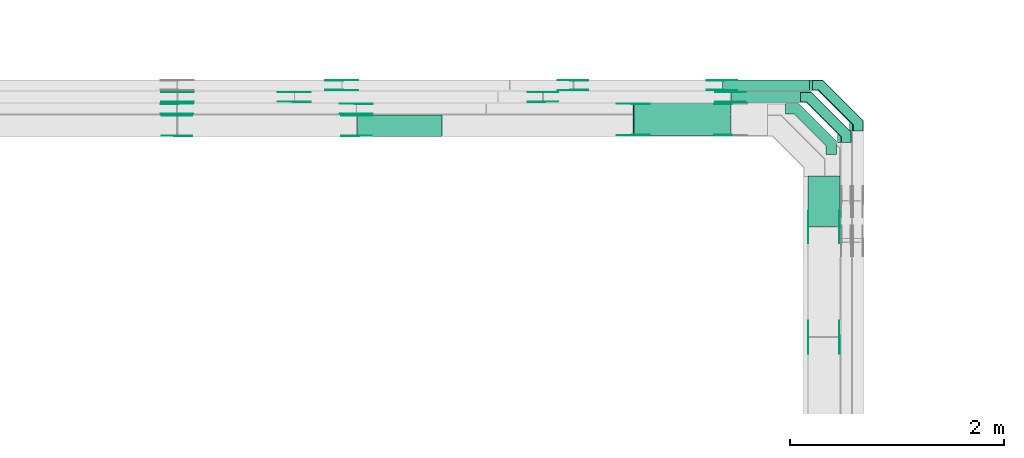
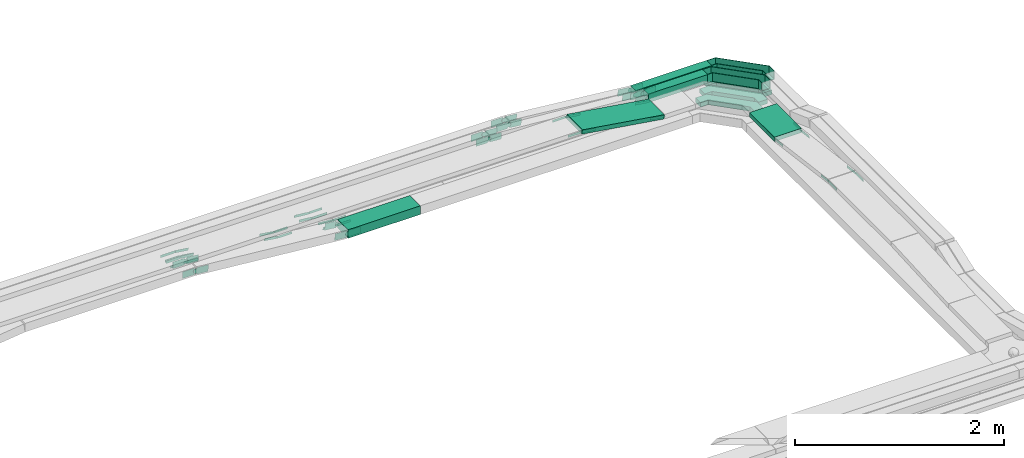
# One storey, part 24 of 33: 63 flow fittings, 5 flow segments.
"""IFC2X3 building model written with IfcOpenShell, lengths in millimetres."""

from ifc_helpers import new_model, entity, si_unit, converted_unit, derived_unit, direction, frame, frame_2d, origin, origin_2d_with_axis, place, context, subcontext, project, spatial, polyline, circle_curve, parameter, trimmed, segment, composite_curve, rectangle, outline, extrude, faceted_brep, source, transform, mapped, material, type_object, type_shapes, element, save


model = new_model("IFC2X3")

# Units and contexts
model_context = context("Model", 3, precision=0.01, world=origin(), true_north=direction((6.12303176911189e-17, 1.0)))
body_context = subcontext(model_context, "Body", "Model", "MODEL_VIEW")
ifc_project = project(units=[si_unit("LENGTHUNIT", "METRE", prefix="MILLI"), si_unit("AREAUNIT", "SQUARE_METRE"), si_unit("VOLUMEUNIT", "CUBIC_METRE"), converted_unit("PLANEANGLEUNIT", "DEGREE", entity("IfcRatioMeasure", 0.0174532925199433), si_unit("PLANEANGLEUNIT", "RADIAN"), dimensions=[0, 0, 0, 0, 0, 0, 0]), si_unit("MASSUNIT", "GRAM", prefix="KILO"), derived_unit("MASSDENSITYUNIT", [(si_unit("MASSUNIT", "GRAM", prefix="KILO"), 1), (si_unit("LENGTHUNIT", "METRE"), -3)]), derived_unit("MOMENTOFINERTIAUNIT", [(si_unit("LENGTHUNIT", "METRE"), 4)]), si_unit("TIMEUNIT", "SECOND"), si_unit("FREQUENCYUNIT", "HERTZ"), si_unit("THERMODYNAMICTEMPERATUREUNIT", "DEGREE_CELSIUS"), derived_unit("THERMALTRANSMITTANCEUNIT", [(si_unit("MASSUNIT", "GRAM", prefix="KILO"), 1), (si_unit("THERMODYNAMICTEMPERATUREUNIT", "KELVIN"), -1), (si_unit("TIMEUNIT", "SECOND"), -3)]), derived_unit("VOLUMETRICFLOWRATEUNIT", [(si_unit("LENGTHUNIT", "METRE"), 3), (si_unit("TIMEUNIT", "SECOND"), -1)]), derived_unit("MASSFLOWRATEUNIT", [(si_unit("MASSUNIT", "GRAM", prefix="KILO"), 1), (si_unit("TIMEUNIT", "SECOND"), -1)]), derived_unit("ROTATIONALFREQUENCYUNIT", [(si_unit("TIMEUNIT", "SECOND"), -1)]), si_unit("ELECTRICCURRENTUNIT", "AMPERE"), si_unit("ELECTRICVOLTAGEUNIT", "VOLT"), si_unit("POWERUNIT", "WATT"), si_unit("FORCEUNIT", "NEWTON", prefix="KILO"), si_unit("ILLUMINANCEUNIT", "LUX"), si_unit("LUMINOUSFLUXUNIT", "LUMEN"), si_unit("LUMINOUSINTENSITYUNIT", "CANDELA"), derived_unit("USERDEFINED", [(si_unit("MASSUNIT", "GRAM", prefix="KILO"), -1), (si_unit("LENGTHUNIT", "METRE"), -2), (si_unit("TIMEUNIT", "SECOND"), 3), (si_unit("LUMINOUSFLUXUNIT", "LUMEN"), 1)]), derived_unit("LINEARVELOCITYUNIT", [(si_unit("LENGTHUNIT", "METRE"), 1), (si_unit("TIMEUNIT", "SECOND"), -1)]), si_unit("PRESSUREUNIT", "PASCAL"), derived_unit("USERDEFINED", [(si_unit("LENGTHUNIT", "METRE"), -2), (si_unit("MASSUNIT", "GRAM", prefix="KILO"), 1), (si_unit("TIMEUNIT", "SECOND"), -2)]), derived_unit("LINEARFORCEUNIT", [(si_unit("MASSUNIT", "GRAM", prefix="KILO"), 1), (si_unit("LENGTHUNIT", "METRE"), 1), (si_unit("TIMEUNIT", "SECOND"), -2), (si_unit("LENGTHUNIT", "METRE"), -1)]), derived_unit("PLANARFORCEUNIT", [(si_unit("MASSUNIT", "GRAM", prefix="KILO"), 1), (si_unit("LENGTHUNIT", "METRE"), 1), (si_unit("TIMEUNIT", "SECOND"), -2), (si_unit("LENGTHUNIT", "METRE"), -2)])], contexts=[model_context])

# Site, building, storey
site_placement = place(None, frame((0.0, -0.00077364408347762, 0.0)))
site = spatial("IfcSite", under=ifc_project, at=site_placement, CompositionType="ELEMENT")
building_placement = place(site_placement, origin())
building = spatial("IfcBuilding", under=site, at=building_placement, CompositionType="ELEMENT")
storey_placement = place(building_placement, frame((0.0, 0.0, 8100.0)))
storey = spatial("IfcBuildingStorey", under=building, at=storey_placement, CompositionType="ELEMENT", Elevation=8100.0)

# Flow segments
cable_carrier_segment_type = type_object("IfcCableCarrierSegmentType", PredefinedType="CABLETRAYSEGMENT")
flow_segment_1_placement = place(storey_placement, frame((60300.1085349485, 13331.1031876468, 2714.71648655332)))
element("IfcFlowSegment", 1, at=flow_segment_1_placement, inside=storey, type_object=cable_carrier_segment_type, context=body_context, shape_type="SweptSolid", body=[
    extrude(rectangle(XDim=475.175048101331, YDim=300.000000000001, at=frame_2d((0.0, -4.33431068813661e-12), x_axis=(1.0, 0.0))), frame((150.0, 237.587524050669, 0.0), z_axis=(0.0, 0.0, 1.0), x_axis=(0.0, 1.0, 0.0)), (0.0, 0.0, 1.0), 50.0000000000016),
])
flow_segment_2_placement = place(storey_placement, frame((58669.0512269878, 14182.2782357481, 2715.49592613957)))
element("IfcFlowSegment", 2, at=flow_segment_2_placement, inside=storey, type_object=cable_carrier_segment_type, context=body_context, shape_type="SweptSolid", body=[
    extrude(rectangle(XDim=50.0000000000009, YDim=300.000000000001, at=origin_2d_with_axis()), frame((3.79996302076238, 150.0, 163.512455206474), z_axis=(0.988380721010554, 0.0, -0.151998520830492), x_axis=(0.151998520830492, 0.0, 0.988380721010554)), (0.0, 0.0, 1.0), 913.186104856669),
])
flow_segment_3_placement = place(storey_placement, frame((56085.8966669019, 14174.499226356, 2550.0)))
element("IfcFlowSegment", 3, at=flow_segment_3_placement, inside=storey, type_object=cable_carrier_segment_type, context=body_context, shape_type="SweptSolid", body=[
    extrude(rectangle(XDim=796.941868051788, YDim=199.999999999998, at=frame_2d((0.0, -1.08002495835535e-12), x_axis=(1.0, 0.0))), frame((398.470934025894, 100.0, 0.0), z_axis=(0.0, 0.0, 1.0), x_axis=(-1.0, 0.0, 0.0)), (0.0, 0.0, 1.0), 99.9999999999989),
])
flow_segment_4_placement = place(storey_placement, frame((59582.4645884858, 14492.2782357478, 2715.06307654173)))
element("IfcFlowSegment", 4, at=flow_segment_4_placement, inside=storey, type_object=cable_carrier_segment_type, context=body_context, shape_type="SweptSolid", body=[
    extrude(rectangle(XDim=651.643946462782, YDim=99.9999999999989, at=frame_2d((0.0, 1.08357767203415e-12), x_axis=(1.0, 0.0))), frame((325.821973231391, 50.0, 0.0)), (0.0, 0.0, 1.0), 99.9999999999989),
])
flow_segment_5_placement = place(storey_placement, frame((59505.1211492045, 14602.2782357478, 2715.099501668)))
element("IfcFlowSegment", 5, at=flow_segment_5_placement, inside=storey, type_object=cable_carrier_segment_type, context=body_context, shape_type="SweptSolid", body=[
    extrude(rectangle(XDim=838.987381608531, YDim=99.9999999999989, at=frame_2d((4.34852154285181e-12, 0.0), x_axis=(1.0, 0.0))), frame((419.49369080426, 50.0, 3.46968127360015e-05)), (0.0, 0.0, 1.0), 99.9999999999993),
])

# Flow fittings
ifc_material_1 = material(Name="G")
cable_carrier_fitting_type_1 = type_object("IfcCableCarrierFittingType", PredefinedType="NOTDEFINED", material=ifc_material_1)
shared_shape_1 = source(origin(), body_context, "Body", "SweptSolid", [
    extrude(outline(composite_curve([segment(trimmed(circle_curve(frame_2d((-44.5901162790698, 0.0), x_axis=(1.0, 0.0)), 12.5), [parameter(90.0000000000007)], [parameter(270.0)], True, "PARAMETER"), True, "CONTINUOUS"), segment(polyline([(-44.5901162790697, -12.5), (-33.0901162790698, -12.5)]), True, "CONTINUOUS"), segment(polyline([(-33.0901162790698, -12.5), (-31.2296511627907, -14.5)]), True, "CONTINUOUS"), segment(polyline([(-31.2296511627907, -14.5), (108.90988372093, -14.5)]), True, "CONTINUOUS"), segment(polyline([(108.90988372093, -14.5), (108.90988372093, 14.5)]), True, "CONTINUOUS"), segment(polyline([(108.90988372093, 14.5), (-31.2296511627907, 14.5)]), True, "CONTINUOUS"), segment(polyline([(-31.2296511627907, 14.5), (-33.0901162790698, 12.5)]), True, "CONTINUOUS"), segment(polyline([(-33.0901162790698, 12.5), (-44.5901162790699, 12.5)]), True, "CONTINUOUS")], self_intersect=False)), frame((44.5901162790698, 0.0, 0.0), z_axis=(0.0, 0.0, -1.0), x_axis=(1.0, 0.0, 0.0)), (0.0, 0.0, -1.0), 2.0),
])
type_shapes(cable_carrier_fitting_type_1, [shared_shape_1])
for number, where, z_axis, x_axis in (
    (6, (55946.4929799907, 14606.8182357371, 2575.0), (0.0, -1.0, 0.0), (1.0, 0.0, 0.0)),
    (7, (55500.7859416605, 14496.8182357372, 2575.0), (0.0, -1.0, 0.0), (1.0, 0.0, 0.0)),
    (8, (56082.4130823039, 14477.7382357575, 2575.0), (0.0, 1.0, 0.0), (-0.995808315172802, 0.0, 0.0914647442062012)),
    (9, (54409.8342324548, 14587.7382357575, 2729.0228574609), (0.0, 1.0, 0.0), (0.990180361963895, 0.0, -0.13979574664864)),
    (10, (54405.4671499451, 14477.7382357575, 2729.02706365649), (0.0, 1.0, 0.0), (0.995808315172802, 0.0, -0.0914647442062012)),
    (11, (60595.5685349587, 12298.2782357482, 2874.70764721448), (1.0, 0.0, 0.0), (0.0, -1.0, 0.0)),
    (12, (58669.6717098796, 14186.8182357379, 2879.49733895757), (0.0, -1.0, 0.0), (-1.0, 0.0, 0.0)),
    (13, (60595.5685349587, 13328.2107948665, 2739.71648655331), (1.0, 0.0, 0.0), (0.0, 1.0, 0.0)),
):
    element("IfcFlowFitting", number, at=place(storey_placement, frame(where, z_axis=z_axis, x_axis=x_axis)), inside=storey, type_object=cable_carrier_fitting_type_1, material=ifc_material_1, context=body_context, shape_type="MappedRepresentation", body=[
        mapped(shared_shape_1, transform((0.0, 0.0, 0.0), scale=1.0)),
    ])
cable_carrier_fitting_type_2 = type_object("IfcCableCarrierFittingType", PredefinedType="NOTDEFINED", material=ifc_material_1)
shared_shape_2 = source(origin(), body_context, "Body", "SweptSolid", [
    extrude(outline(composite_curve([segment(trimmed(circle_curve(frame_2d((-44.5901162790697, 0.0), x_axis=(1.0, 0.0)), 12.5), [parameter(90.0000000000007)], [parameter(270.0)], True, "PARAMETER"), True, "CONTINUOUS"), segment(polyline([(-44.5901162790697, -12.5), (-33.0901162790697, -12.5)]), True, "CONTINUOUS"), segment(polyline([(-33.0901162790697, -12.5), (-31.2296511627907, -14.5)]), True, "CONTINUOUS"), segment(polyline([(-31.2296511627907, -14.5), (108.90988372093, -14.5)]), True, "CONTINUOUS"), segment(polyline([(108.90988372093, -14.5), (108.90988372093, 14.5)]), True, "CONTINUOUS"), segment(polyline([(108.90988372093, 14.5), (-31.2296511627907, 14.5)]), True, "CONTINUOUS"), segment(polyline([(-31.2296511627907, 14.5), (-33.0901162790698, 12.5)]), True, "CONTINUOUS"), segment(polyline([(-33.0901162790698, 12.5), (-44.5901162790699, 12.5)]), True, "CONTINUOUS")], self_intersect=False)), frame((44.5901162790697, 0.0, 0.0)), (0.0, 0.0, 1.0), 2.0),
])
type_shapes(cable_carrier_fitting_type_2, [shared_shape_2])
for number, where, z_axis, x_axis in (
    (14, (55946.4929799907, 14697.7382357574, 2575.0), (0.0, 1.0, 0.0), (1.0, 0.0, 0.0)),
    (15, (55500.7859416605, 14587.7382357575, 2575.0), (0.0, 1.0, 0.0), (1.0, 0.0, 0.0)),
    (16, (56082.4130823039, 14386.8182357372, 2575.0), (0.0, -1.0, 0.0), (-0.995808315172802, 0.0, 0.0914647442062012)),
    (17, (54409.8342324548, 14496.8182357372, 2729.0228574609), (0.0, -1.0, 0.0), (0.990180361963895, 0.0, -0.13979574664864)),
    (18, (54405.4671499451, 14386.8182357372, 2729.02706365649), (0.0, -1.0, 0.0), (0.995808315172802, 0.0, -0.0914647442062012)),
    (19, (60304.6485349384, 12298.2782357482, 2874.70764721448), (-1.0, 0.0, 0.0), (0.0, -1.0, 0.0)),
    (20, (58669.6717098796, 14477.7382357583, 2879.49733895757), (0.0, 1.0, 0.0), (-1.0, 0.0, 0.0)),
    (21, (60304.6485349384, 13328.2107948665, 2739.71648655331), (-1.0, 0.0, 0.0), (0.0, 1.0, 0.0)),
):
    element("IfcFlowFitting", number, at=place(storey_placement, frame(where, z_axis=z_axis, x_axis=x_axis)), inside=storey, type_object=cable_carrier_fitting_type_2, material=ifc_material_1, context=body_context, shape_type="MappedRepresentation", body=[
        mapped(shared_shape_2, transform((0.0, 0.0, 0.0), scale=1.0)),
    ])
cable_carrier_fitting_type_3 = type_object("IfcCableCarrierFittingType", PredefinedType="NOTDEFINED", material=ifc_material_1)
shared_shape_3 = source(origin(), body_context, "Body", "SweptSolid", [
    extrude(outline(composite_curve([segment(trimmed(circle_curve(frame_2d((-44.5901162790698, 0.0), x_axis=(1.0, 0.0)), 12.5), [parameter(90.0000000000007)], [parameter(270.0)], True, "PARAMETER"), True, "CONTINUOUS"), segment(polyline([(-44.5901162790697, -12.5), (-33.0901162790698, -12.5)]), True, "CONTINUOUS"), segment(polyline([(-33.0901162790698, -12.5), (-31.2296511627907, -14.5)]), True, "CONTINUOUS"), segment(polyline([(-31.2296511627907, -14.5), (108.90988372093, -14.5)]), True, "CONTINUOUS"), segment(polyline([(108.90988372093, -14.5), (108.90988372093, 14.5)]), True, "CONTINUOUS"), segment(polyline([(108.90988372093, 14.5), (-31.2296511627907, 14.5)]), True, "CONTINUOUS"), segment(polyline([(-31.2296511627907, 14.5), (-33.0901162790698, 12.5)]), True, "CONTINUOUS"), segment(polyline([(-33.0901162790698, 12.5), (-44.5901162790699, 12.5)]), True, "CONTINUOUS")], self_intersect=False)), frame((44.5901162790698, 0.0, 0.0), z_axis=(0.0, 0.0, -1.0), x_axis=(1.0, 0.0, 0.0)), (0.0, 0.0, -1.0), 2.0),
])
type_shapes(cable_carrier_fitting_type_3, [shared_shape_3])
for number, where, z_axis, x_axis in (
    (22, (55946.4929799907, 14695.7382357574, 2575.0), (0.0, 1.0, 0.0), (-0.995008976454968, 0.0, 0.099785453719652)),
    (23, (55500.7859416606, 14585.7382357575, 2575.0), (0.0, 1.0, 0.0), (-0.990180361963207, 0.0, 0.139795746653509)),
    (24, (56082.4130823038, 14388.8182357372, 2575.0), (0.0, -1.0, 0.0), (1.0, 0.0, 0.0)),
    (25, (54409.8342324548, 14498.8182357372, 2729.02285746089), (0.0, -1.0, 0.0), (-1.0, 0.0, 0.0)),
    (26, (54405.4671499451, 14388.8182357372, 2729.02706365649), (0.0, -1.0, 0.0), (-1.0, 0.0, 0.0)),
    (27, (60306.6485349383, 12298.2782357482, 2874.70764721447), (-1.0, 0.0, 0.0), (0.0, 0.99151970078222, -0.129956465636523)),
    (28, (58669.6717098796, 14475.7382357583, 2879.49733895756), (0.0, 1.0, 0.0), (0.98838072101055, 0.0, -0.151998520830521)),
    (29, (60306.6485349383, 13328.2107948666, 2739.71648655331), (-1.0, 0.0, 0.0), (0.0, -0.991519700782225, 0.129956465636488)),
    (30, (59578.6062108725, 14475.7382357583, 2739.71648655331), (0.0, 1.0, 0.0), (-0.98838072101055, 0.0, 0.151998520830518)),
):
    element("IfcFlowFitting", number, at=place(storey_placement, frame(where, z_axis=z_axis, x_axis=x_axis)), inside=storey, type_object=cable_carrier_fitting_type_3, material=ifc_material_1, context=body_context, shape_type="MappedRepresentation", body=[
        mapped(shared_shape_3, transform((0.0, 0.0, 0.0), scale=1.0)),
    ])
cable_carrier_fitting_type_4 = type_object("IfcCableCarrierFittingType", PredefinedType="NOTDEFINED", material=ifc_material_1)
shared_shape_4 = source(origin(), body_context, "Body", "SweptSolid", [
    extrude(outline(composite_curve([segment(trimmed(circle_curve(frame_2d((-44.5901162790697, 0.0), x_axis=(1.0, 0.0)), 12.5), [parameter(90.0000000000007)], [parameter(270.0)], True, "PARAMETER"), True, "CONTINUOUS"), segment(polyline([(-44.5901162790697, -12.5), (-33.0901162790697, -12.5)]), True, "CONTINUOUS"), segment(polyline([(-33.0901162790697, -12.5), (-31.2296511627907, -14.5)]), True, "CONTINUOUS"), segment(polyline([(-31.2296511627907, -14.5), (108.90988372093, -14.5)]), True, "CONTINUOUS"), segment(polyline([(108.90988372093, -14.5), (108.90988372093, 14.5)]), True, "CONTINUOUS"), segment(polyline([(108.90988372093, 14.5), (-31.2296511627907, 14.5)]), True, "CONTINUOUS"), segment(polyline([(-31.2296511627907, 14.5), (-33.0901162790698, 12.5)]), True, "CONTINUOUS"), segment(polyline([(-33.0901162790698, 12.5), (-44.5901162790699, 12.5)]), True, "CONTINUOUS")], self_intersect=False)), frame((44.5901162790697, 0.0, 0.0)), (0.0, 0.0, 1.0), 2.0),
])
type_shapes(cable_carrier_fitting_type_4, [shared_shape_4])
for number, where, z_axis, x_axis in (
    (31, (55946.4929799907, 14608.8182357371, 2575.0), (0.0, -1.0, 0.0), (-0.995008976454968, 0.0, 0.099785453719652)),
    (32, (55500.7859416606, 14498.8182357372, 2575.0), (0.0, -1.0, 0.0), (-0.990180361963207, 0.0, 0.139795746653509)),
    (33, (56082.4130823038, 14475.7382357575, 2575.0), (0.0, 1.0, 0.0), (1.0, 0.0, 0.0)),
    (34, (54409.8342324548, 14585.7382357575, 2729.02285746089), (0.0, 1.0, 0.0), (-1.0, 0.0, 0.0)),
    (35, (54405.4671499451, 14475.7382357575, 2729.02706365649), (0.0, 1.0, 0.0), (-1.0, 0.0, 0.0)),
    (36, (60593.5685349587, 12298.2782357482, 2874.70764721447), (1.0, 0.0, 0.0), (0.0, 0.99151970078222, -0.129956465636523)),
    (37, (58669.6717098796, 14188.818235738, 2879.49733895756), (0.0, -1.0, 0.0), (0.98838072101055, 0.0, -0.151998520830521)),
    (38, (60593.5685349587, 13328.2107948666, 2739.71648655331), (1.0, 0.0, 0.0), (0.0, -0.991519700782225, 0.129956465636488)),
    (39, (59578.6062108725, 14188.818235738, 2739.71648655331), (0.0, -1.0, 0.0), (-0.98838072101055, 0.0, 0.151998520830518)),
):
    element("IfcFlowFitting", number, at=place(storey_placement, frame(where, z_axis=z_axis, x_axis=x_axis)), inside=storey, type_object=cable_carrier_fitting_type_4, material=ifc_material_1, context=body_context, shape_type="MappedRepresentation", body=[
        mapped(shared_shape_4, transform((0.0, 0.0, 0.0), scale=1.0)),
    ])
cable_carrier_fitting_type_5 = type_object("IfcCableCarrierFittingType", PredefinedType="NOTDEFINED", material=ifc_material_1)
shared_shape_5 = source(origin(), body_context, "Body", "SweptSolid", [
    extrude(outline(composite_curve([segment(trimmed(circle_curve(frame_2d((-41.4651162790697, 0.0), x_axis=(1.0, 0.0)), 25.0), [parameter(90.0000000000007)], [parameter(270.0)], True, "PARAMETER"), True, "CONTINUOUS"), segment(polyline([(-41.4651162790697, -25.0), (-29.9651162790697, -25.0)]), True, "CONTINUOUS"), segment(polyline([(-29.9651162790697, -25.0), (-28.1046511627907, -38.5)]), True, "CONTINUOUS"), segment(polyline([(-28.1046511627907, -38.5), (99.5348837209303, -38.5)]), True, "CONTINUOUS"), segment(polyline([(99.5348837209303, -38.5), (99.5348837209303, 38.5)]), True, "CONTINUOUS"), segment(polyline([(99.5348837209303, 38.5), (-28.1046511627907, 38.5)]), True, "CONTINUOUS"), segment(polyline([(-28.1046511627907, 38.5), (-29.9651162790697, 25.0)]), True, "CONTINUOUS"), segment(polyline([(-29.9651162790697, 25.0), (-41.46511627907, 25.0)]), True, "CONTINUOUS")], self_intersect=False)), frame((41.4651162790697, 0.0, 0.0), z_axis=(0.0, 0.0, -1.0), x_axis=(1.0, 0.0, 0.0)), (0.0, 0.0, -1.0), 2.0),
])
type_shapes(cable_carrier_fitting_type_5, [shared_shape_5])
for number, where, z_axis, x_axis in (
    (40, (57822.9130823037, 14496.8182357376, 2905.0), (0.0, -1.0, 0.0), (-1.0, 0.0, 0.0)),
    (41, (58106.4054327808, 14606.8182357376, 2905.0), (0.0, -1.0, 0.0), (-1.0, 0.0, 0.0)),
    (42, (56082.4130823039, 14369.9592263662, 2600.0), (0.0, 1.0, 0.0), (-0.995778345359127, 0.0, 0.091790451103799)),
    (43, (54405.4832294798, 14369.9592263662, 2754.57872565434), (0.0, 1.0, 0.0), (0.995778345359127, 0.0, -0.091790451103799)),
    (44, (59501.4202080822, 14606.8182357376, 2765.09957136772), (0.0, -1.0, 0.0), (1.0, 0.0, -8.27111719114981e-08)),
    (45, (59579.3168362892, 14496.8182357376, 2765.06307654172), (0.0, -1.0, 0.0), (1.0, 0.0, 0.0)),
):
    element("IfcFlowFitting", number, at=place(storey_placement, frame(where, z_axis=z_axis, x_axis=x_axis)), inside=storey, type_object=cable_carrier_fitting_type_5, material=ifc_material_1, context=body_context, shape_type="MappedRepresentation", body=[
        mapped(shared_shape_5, transform((0.0, 0.0, 0.0), scale=1.0)),
    ])
cable_carrier_fitting_type_6 = type_object("IfcCableCarrierFittingType", PredefinedType="NOTDEFINED", material=ifc_material_1)
shared_shape_6 = source(origin(), body_context, "Body", "SweptSolid", [
    extrude(outline(composite_curve([segment(trimmed(circle_curve(frame_2d((-41.4651162790697, 0.0), x_axis=(1.0, 0.0)), 25.0), [parameter(90.0000000000007)], [parameter(270.0)], True, "PARAMETER"), True, "CONTINUOUS"), segment(polyline([(-41.4651162790697, -25.0), (-29.9651162790697, -25.0)]), True, "CONTINUOUS"), segment(polyline([(-29.9651162790697, -25.0), (-28.1046511627907, -38.5)]), True, "CONTINUOUS"), segment(polyline([(-28.1046511627907, -38.5), (99.5348837209303, -38.5)]), True, "CONTINUOUS"), segment(polyline([(99.5348837209303, -38.5), (99.5348837209303, 38.5)]), True, "CONTINUOUS"), segment(polyline([(99.5348837209303, 38.5), (-28.1046511627907, 38.5)]), True, "CONTINUOUS"), segment(polyline([(-28.1046511627907, 38.5), (-29.9651162790697, 25.0)]), True, "CONTINUOUS"), segment(polyline([(-29.9651162790697, 25.0), (-41.46511627907, 25.0)]), True, "CONTINUOUS")], self_intersect=False)), frame((41.4651162790697, 0.0, 0.0)), (0.0, 0.0, 1.0), 2.0),
])
type_shapes(cable_carrier_fitting_type_6, [shared_shape_6])
for number, where, z_axis, x_axis in (
    (46, (57822.9130823037, 14587.7382357579, 2905.0), (0.0, 1.0, 0.0), (-1.0, 0.0, 0.0)),
    (47, (58106.4054327808, 14697.7382357579, 2905.0), (0.0, 1.0, 0.0), (-1.0, 0.0, 0.0)),
    (48, (56082.4130823039, 14179.0392263459, 2600.0), (0.0, -1.0, 0.0), (-0.995778345359127, 0.0, 0.091790451103799)),
    (49, (54405.4832294798, 14179.0392263459, 2754.57872565435), (0.0, -1.0, 0.0), (0.995778345359127, 0.0, -0.091790451103799)),
    (50, (59501.4202080822, 14697.7382357579, 2765.09957136772), (0.0, 1.0, 0.0), (1.0, 0.0, -8.27111719114981e-08)),
    (51, (59579.3168362892, 14587.7382357579, 2765.06307654171), (0.0, 1.0, 0.0), (1.0, 0.0, 0.0)),
):
    element("IfcFlowFitting", number, at=place(storey_placement, frame(where, z_axis=z_axis, x_axis=x_axis)), inside=storey, type_object=cable_carrier_fitting_type_6, material=ifc_material_1, context=body_context, shape_type="MappedRepresentation", body=[
        mapped(shared_shape_6, transform((0.0, 0.0, 0.0), scale=1.0)),
    ])
cable_carrier_fitting_type_7 = type_object("IfcCableCarrierFittingType", PredefinedType="NOTDEFINED", material=ifc_material_1)
shared_shape_7 = source(origin(), body_context, "Body", "SweptSolid", [
    extrude(outline(composite_curve([segment(trimmed(circle_curve(frame_2d((-41.4651162790697, 0.0), x_axis=(1.0, 0.0)), 25.0), [parameter(90.0000000000007)], [parameter(270.0)], True, "PARAMETER"), True, "CONTINUOUS"), segment(polyline([(-41.4651162790697, -25.0), (-29.9651162790697, -25.0)]), True, "CONTINUOUS"), segment(polyline([(-29.9651162790697, -25.0), (-28.1046511627907, -38.5)]), True, "CONTINUOUS"), segment(polyline([(-28.1046511627907, -38.5), (99.5348837209303, -38.5)]), True, "CONTINUOUS"), segment(polyline([(99.5348837209303, -38.5), (99.5348837209303, 38.5)]), True, "CONTINUOUS"), segment(polyline([(99.5348837209303, 38.5), (-28.1046511627907, 38.5)]), True, "CONTINUOUS"), segment(polyline([(-28.1046511627907, 38.5), (-29.9651162790697, 25.0)]), True, "CONTINUOUS"), segment(polyline([(-29.9651162790697, 25.0), (-41.46511627907, 25.0)]), True, "CONTINUOUS")], self_intersect=False)), frame((41.4651162790697, 0.0, 0.0), z_axis=(0.0, 0.0, -1.0), x_axis=(1.0, 0.0, 0.0)), (0.0, 0.0, -1.0), 2.0),
])
type_shapes(cable_carrier_fitting_type_7, [shared_shape_7])
for number, where, z_axis, x_axis in (
    (52, (57822.9130823037, 14585.7382357579, 2905.0), (0.0, 1.0, 0.0), (0.996841183853236, 0.0, -0.0794207414601401)),
    (53, (58106.4054327807, 14695.7382357579, 2905.0), (0.0, 1.0, 0.0), (0.995008976454974, 0.0, -0.0997854537195949)),
    (54, (56082.4130823038, 14181.0392263459, 2600.0), (0.0, -1.0, 0.0), (1.0, 0.0, 0.0)),
    (55, (54405.4832294798, 14181.0392263459, 2754.57872565434), (0.0, -1.0, 0.0), (-1.0, 0.0, 0.0)),
    (56, (59501.4202080822, 14695.7382357579, 2765.09957136772), (0.0, 1.0, 0.0), (-0.995008976454974, 0.0, 0.0997854537195905)),
    (57, (59579.3168362892, 14585.7382357579, 2765.06307654172), (0.0, 1.0, 0.0), (-0.996841183853237, 0.0, 0.0794207414601364)),
):
    element("IfcFlowFitting", number, at=place(storey_placement, frame(where, z_axis=z_axis, x_axis=x_axis)), inside=storey, type_object=cable_carrier_fitting_type_7, material=ifc_material_1, context=body_context, shape_type="MappedRepresentation", body=[
        mapped(shared_shape_7, transform((0.0, 0.0, 0.0), scale=1.0)),
    ])
cable_carrier_fitting_type_8 = type_object("IfcCableCarrierFittingType", PredefinedType="NOTDEFINED", material=ifc_material_1)
shared_shape_8 = source(origin(), body_context, "Body", "SweptSolid", [
    extrude(outline(composite_curve([segment(trimmed(circle_curve(frame_2d((-41.4651162790697, 0.0), x_axis=(1.0, 0.0)), 25.0), [parameter(90.0000000000007)], [parameter(270.0)], True, "PARAMETER"), True, "CONTINUOUS"), segment(polyline([(-41.4651162790697, -25.0), (-29.9651162790697, -25.0)]), True, "CONTINUOUS"), segment(polyline([(-29.9651162790697, -25.0), (-28.1046511627907, -38.5)]), True, "CONTINUOUS"), segment(polyline([(-28.1046511627907, -38.5), (99.5348837209303, -38.5)]), True, "CONTINUOUS"), segment(polyline([(99.5348837209303, -38.5), (99.5348837209303, 38.5)]), True, "CONTINUOUS"), segment(polyline([(99.5348837209303, 38.5), (-28.1046511627907, 38.5)]), True, "CONTINUOUS"), segment(polyline([(-28.1046511627907, 38.5), (-29.9651162790697, 25.0)]), True, "CONTINUOUS"), segment(polyline([(-29.9651162790697, 25.0), (-41.46511627907, 25.0)]), True, "CONTINUOUS")], self_intersect=False)), frame((41.4651162790697, 0.0, 0.0)), (0.0, 0.0, 1.0), 2.0),
])
type_shapes(cable_carrier_fitting_type_8, [shared_shape_8])
for number, where, z_axis, x_axis in (
    (58, (57822.9130823037, 14498.8182357376, 2905.0), (0.0, -1.0, 0.0), (0.996841183853236, 0.0, -0.0794207414601401)),
    (59, (58106.4054327807, 14608.8182357376, 2905.0), (0.0, -1.0, 0.0), (0.995008976454974, 0.0, -0.0997854537195949)),
    (60, (56082.4130823038, 14367.9592263662, 2600.0), (0.0, 1.0, 0.0), (1.0, 0.0, 0.0)),
    (61, (54405.4832294798, 14367.9592263662, 2754.57872565434), (0.0, 1.0, 0.0), (-1.0, 0.0, 0.0)),
    (62, (59501.4202080822, 14608.8182357376, 2765.09957136772), (0.0, -1.0, 0.0), (-0.995008976454974, 0.0, 0.0997854537195905)),
    (63, (59579.3168362892, 14498.8182357376, 2765.06307654172), (0.0, -1.0, 0.0), (-0.996841183853237, 0.0, 0.0794207414601364)),
):
    element("IfcFlowFitting", number, at=place(storey_placement, frame(where, z_axis=z_axis, x_axis=x_axis)), inside=storey, type_object=cable_carrier_fitting_type_8, material=ifc_material_1, context=body_context, shape_type="MappedRepresentation", body=[
        mapped(shared_shape_8, transform((0.0, 0.0, 0.0), scale=1.0)),
    ])
ifc_material_2 = material()
cable_carrier_fitting_type_9 = type_object("IfcCableCarrierFittingType", Name="470_DKC_G5_Sheet horizontal bend:-", PredefinedType="NOTDEFINED", material=ifc_material_2)
shared_shape_9 = source(origin(), body_context, "Body", "SweptSolid", [
    extrude(outline(polyline([(-238.25, -237.749999999999), (-116.539321881345, -237.749999999999), (237.75, 116.539321881345), (237.75, 238.249999999999), (137.75, 238.249999999999), (137.75, 157.960678118654), (-157.960678118654, -137.749999999999), (-238.25, -137.749999999999), (-238.25, -237.749999999999)])), frame((-187.749999999993, 187.749999999989, -25.0)), (0.0, 0.0, 1.0), 50.0000000000003),
])
type_shapes(cable_carrier_fitting_type_9, [shared_shape_9])
for number, where, z_axis, x_axis, name in (
    (64, (60520.1085349486, 14432.2782357473, 2575.0), (0.0, 0.0, 1.0), (0.0, 1.0, 0.0), "470_DKC_G5_Sheet horizontal bend:-"),
    (65, (60630.1085349486, 14542.2782357474, 2575.0), (0.0, 0.0, 1.0), (0.0, 1.0, 0.0), "470_DKC_G5_Sheet horizontal bend:-"),
    (66, (60740.1085349486, 14652.2782357473, 2575.0), (0.0, 0.0, 1.0), (0.0, 1.0, 0.0), "470_DKC_G5_Sheet horizontal bend:-"),
):
    element("IfcFlowFitting", number, at=place(storey_placement, frame(where, z_axis=z_axis, x_axis=x_axis)), inside=storey, type_object=cable_carrier_fitting_type_9, material=ifc_material_2, Name=name, ObjectType="470_DKC_G5_Sheet horizontal bend:-", context=body_context, shape_type="MappedRepresentation", body=[
        mapped(shared_shape_9, transform((0.0, 0.0, 0.0), scale=1.0)),
    ])
cable_carrier_fitting_type_10 = type_object("IfcCableCarrierFittingType", Name="470_DKC_G5_Sheet horizontal bend:-", PredefinedType="NOTDEFINED", material=ifc_material_2)
shared_shape_10 = source(origin(), body_context, "Body", "Brep", [
    faceted_brep([(-426.0, -50.0, -50.0), (-426.0, -50.0, 50.0), (-426.0, -45.0, 50.0), (-426.0, -45.0, -45.0), (-426.0, 45.0, -45.0), (-426.0, 45.0, 50.0), (-426.0, 50.0, 50.0), (-426.0, 50.0, -50.0), (50.0, 426.0, -50.0), (-50.0, 426.0, -50.0), (-50.0, 426.0, 50.0), (-45.0, 426.0, 50.0), (-45.0, 426.0, -45.0), (45.0, 426.0, -45.0), (45.0, 426.0, 50.0), (50.0, 426.0, 50.0), (-329.289321881337, -50.0, -50.0), (-329.289321881337, -50.0, 50.0), (50.0, 329.289321881334, 50.0), (45.0, 331.3603896932, 50.0), (-331.360389693203, -45.0, 50.0), (-331.360389693203, -45.0, -45.0), (45.0, 331.3603896932, -45.0), (-45.0, 368.639610306778, -45.0), (-368.639610306781, 45.0, -45.0), (-368.639610306781, 45.0, 50.0), (-45.0, 368.639610306778, 50.0), (-50.0, 370.710678118644, 50.0), (-370.710678118647, 50.0, 50.0), (-370.710678118647, 50.0, -50.0), (-50.0, 370.710678118644, -50.0), (50.0, 329.289321881334, -50.0)], [[[0, 1, 2, 3, 4, 5, 6, 7]], [[8, 9, 10, 11, 12, 13, 14, 15]], [[1, 0, 16, 17]], [[2, 1, 17, 18, 15, 14, 19, 20]], [[3, 2, 20, 21]], [[4, 3, 21, 22, 13, 12, 23, 24]], [[5, 4, 24, 25]], [[6, 5, 25, 26, 11, 10, 27, 28]], [[7, 6, 28, 29]], [[0, 7, 29, 30, 9, 8, 31, 16]], [[17, 16, 31, 18]], [[21, 20, 19, 22]], [[25, 24, 23, 26]], [[29, 28, 27, 30]], [[18, 31, 8, 15]], [[22, 19, 14, 13]], [[26, 23, 12, 11]], [[30, 27, 10, 9]]]),
])
type_shapes(cable_carrier_fitting_type_10, [shared_shape_10])
for number, where, z_axis, x_axis, name in (
    (67, (60770.1085349486, 14652.2782357478, 2765.099501668), (8.27111670022524e-08, -3.35252266217633e-05, 1.0), (0.0, 1.0, 3.35252266217634e-05), "470_DKC_G5_Sheet horizontal bend:-"),
    (68, (60660.1085349486, 14542.2782357478, 2765.06307654174), (0.0, 0.0, 1.0), (0.0, 1.0, 0.0), "470_DKC_G5_Sheet horizontal bend:-"),
):
    element("IfcFlowFitting", number, at=place(storey_placement, frame(where, z_axis=z_axis, x_axis=x_axis)), inside=storey, type_object=cable_carrier_fitting_type_10, material=ifc_material_2, Name=name, ObjectType="470_DKC_G5_Sheet horizontal bend:-", context=body_context, shape_type="MappedRepresentation", body=[
        mapped(shared_shape_10, transform((0.0, 0.0, 0.0), scale=1.0)),
    ])

save(model, "model.ifc")
